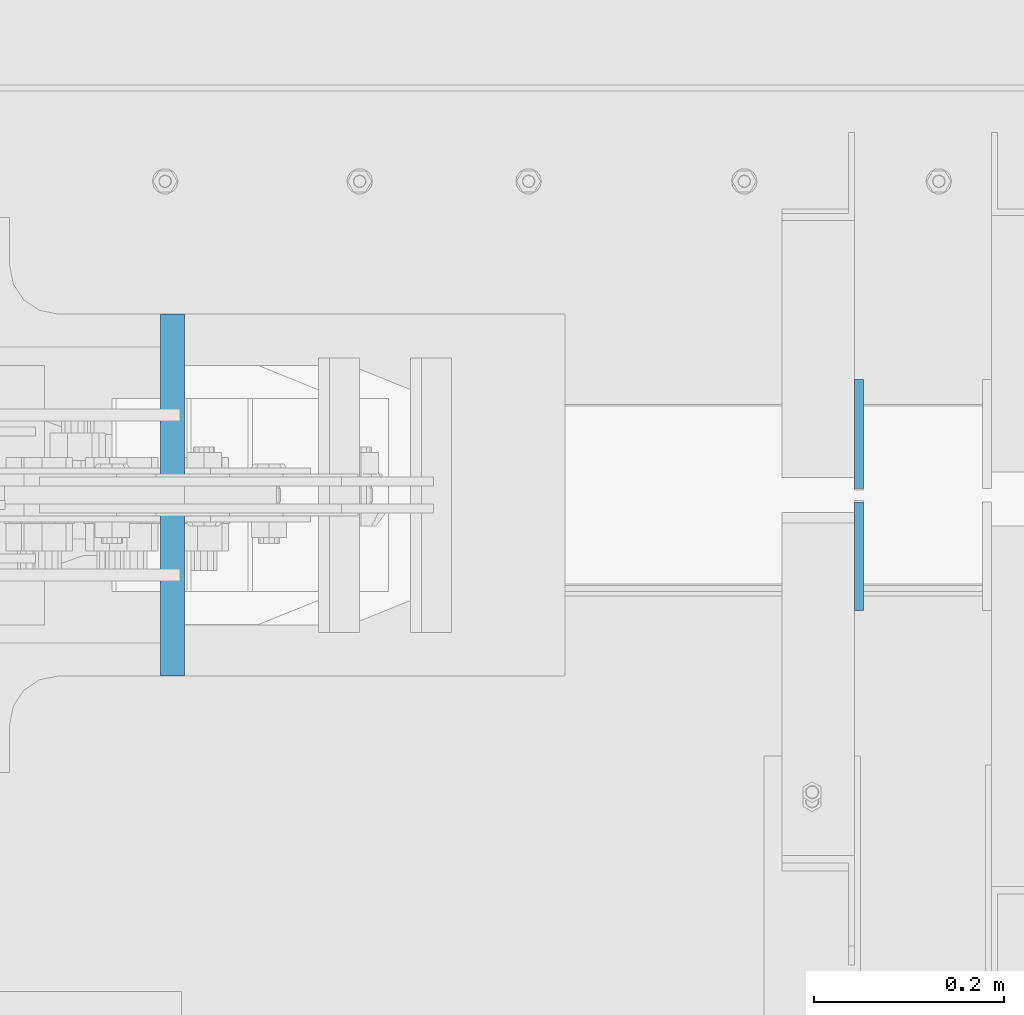
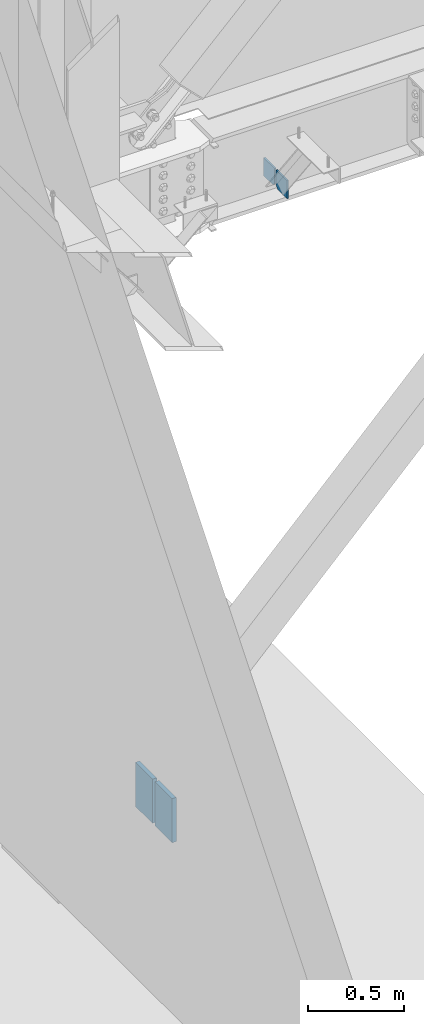
# One storey, part 510 of 1179: 4 columns, 3 elements without a shape of their own.
"""IFC2X3 building model written with IfcOpenShell, lengths in millimetres."""

from ifc_helpers import new_model, si_unit, frame, origin_with_axes, place, context, subcontext, project, spatial, faceted_brep, material, type_object, element, aggregate, save


model = new_model("IFC2X3")

# Units and contexts
model_context = context("Model", 3, precision=1e-05, world=origin_with_axes())
body_context = subcontext(model_context, "Body", "Model", "MODEL_VIEW")
ifc_project = project(units=[si_unit("LENGTHUNIT", "METRE", prefix="MILLI"), si_unit("AREAUNIT", "SQUARE_METRE"), si_unit("VOLUMEUNIT", "CUBIC_METRE"), si_unit("MASSUNIT", "GRAM", prefix="KILO"), si_unit("TIMEUNIT", "SECOND"), si_unit("PLANEANGLEUNIT", "RADIAN"), si_unit("SOLIDANGLEUNIT", "STERADIAN"), si_unit("THERMODYNAMICTEMPERATUREUNIT", "DEGREE_CELSIUS"), si_unit("LUMINOUSINTENSITYUNIT", "LUMEN")], contexts=[model_context])

# Site, building, storey
site_placement = place(None, origin_with_axes())
site = spatial("IfcSite", under=ifc_project, at=site_placement, CompositionType="ELEMENT")
building_placement = place(site_placement, origin_with_axes())
building = spatial("IfcBuilding", under=site, at=building_placement, Name="Undefined", CompositionType="ELEMENT")
storey_placement = place(building_placement, origin_with_axes())
storey = spatial("IfcBuildingStorey", under=building, at=storey_placement, Name="Undefined", CompositionType="ELEMENT", Elevation=0.0)

# Assembly, columns
assembly_1_placement = place(storey_placement, origin_with_axes())
assembly_1 = element("IfcElementAssembly", 1, at=assembly_1_placement, inside=storey, Name="BEAM", AssemblyPlace="NOTDEFINED", PredefinedType="RIGID_FRAME")
ifc_material_1 = material(Name="STEEL/A36")
column_type_1 = type_object("IfcColumnType", PredefinedType="NOTDEFINED")
column_1_placement = place(assembly_1_placement, frame((1617.6625, 41263.09375, 3576.6375), z_axis=(0.0, -1.0, 0.0), x_axis=(0.0, 0.0, 1.0)))
column_1 = element("IfcColumn", 2, at=column_1_placement, type_object=column_type_1, material=ifc_material_1, Name="PLATE", context=body_context, shape_type="Brep", body=[
    faceted_brep([(19.0500000000002, 4.76250000000073, 57.1500000000015), (0.0, 4.76250000000073, 38.0999999999985), (0.0, -4.76250000000073, 38.0999999999985), (19.0500000000002, -4.76250000000073, 57.1500000000015), (114.300000000001, 4.76250000000073, 57.1500000000015), (114.300000000001, 4.76250000000073, -57.1500000000015), (0.0, 4.76250000000073, -57.1500000000015), (114.300000000001, -4.76250000000073, 57.1500000000015), (0.0, -4.76250000000073, -57.1500000000015), (114.300000000001, -4.76250000000073, -57.1500000000015)], [[[0, 1, 2, 3]], [[4, 5, 6, 1, 0]], [[7, 4, 0, 3]], [[8, 9, 7, 3, 2]], [[8, 6, 5, 9]], [[7, 9, 5, 4]], [[6, 8, 2, 1]]]),
])
column_2_placement = place(assembly_1_placement, frame((1617.6625, 41134.50625, 3576.6375), z_axis=(0.0, 1.0, 0.0), x_axis=(0.0, 0.0, 1.0)))
column_2 = element("IfcColumn", 3, at=column_2_placement, type_object=column_type_1, material=ifc_material_1, Name="PLATE", context=body_context, shape_type="Brep", body=[
    faceted_brep([(19.0500000000002, 4.76250000000073, 57.1500000000015), (0.0, 4.76250000000073, 38.0999999999985), (0.0, -4.76250000000073, 38.0999999999985), (19.0500000000002, -4.76250000000073, 57.1500000000015), (114.300000000001, 4.76250000000073, 57.1500000000015), (114.300000000001, 4.76250000000073, -57.1500000000015), (0.0, 4.76250000000073, -57.1500000000015), (114.300000000001, -4.76250000000073, 57.1500000000015), (0.0, -4.76250000000073, -57.1500000000015), (114.300000000001, -4.76250000000073, -57.1500000000015)], [[[0, 1, 2, 3]], [[4, 5, 6, 1, 0]], [[7, 4, 0, 3]], [[8, 9, 7, 3, 2]], [[8, 6, 5, 9]], [[7, 9, 5, 4]], [[6, 8, 2, 1]]]),
])
aggregate(assembly_1, [column_1, column_2])

# Assembly, column
assembly_2_placement = place(storey_placement, origin_with_axes())
assembly_2 = element("IfcElementAssembly", 4, at=assembly_2_placement, inside=storey, Name="PLATE", AssemblyPlace="NOTDEFINED", PredefinedType="RIGID_FRAME")
ifc_material_2 = material(Name="STEEL/A572-GR.50")
column_type_2 = type_object("IfcColumnType", PredefinedType="NOTDEFINED")
column_3_placement = place(assembly_2_placement, frame((895.368453431646, 41300.4, -215.900033118257), z_axis=(0.0, -1.0, 0.0), x_axis=(0.0, 0.0, 1.0)))
column_3 = element("IfcColumn", 5, at=column_3_placement, type_object=column_type_2, material=ifc_material_2, Name="PLATE", context=body_context, shape_type="Brep", body=[
    faceted_brep([(0.0, 12.6999999999998, -88.9000000000015), (0.0, 12.6999999999998, 88.9000000000015), (280.541723827944, 12.6999999999998, 88.9000000000015), (280.541723827944, 12.6999999999998, -88.9000000000015), (0.0, -12.6999999999998, 88.9000000000015), (280.541723827944, -12.6999999999998, 88.9000000000015), (0.0, -12.6999999999998, -88.9000000000015), (280.541723827944, -12.6999999999998, -88.9000000000015)], [[[0, 1, 2, 3]], [[1, 4, 5, 2]], [[4, 6, 7, 5]], [[6, 0, 3, 7]], [[5, 7, 3, 2]], [[6, 4, 1, 0]]]),
])
aggregate(assembly_2, [column_3])

assembly_3_placement = place(storey_placement, origin_with_axes())
assembly_3 = element("IfcElementAssembly", 6, at=assembly_3_placement, inside=storey, Name="PLATE", AssemblyPlace="NOTDEFINED", PredefinedType="RIGID_FRAME")
column_4_placement = place(assembly_3_placement, frame((895.368453431646, 41097.2, -215.900033118257), z_axis=(0.0, 1.0, 0.0), x_axis=(0.0, 0.0, 1.0)))
column_4 = element("IfcColumn", 7, at=column_4_placement, type_object=column_type_2, material=ifc_material_2, Name="PLATE", context=body_context, shape_type="Brep", body=[
    faceted_brep([(0.0, 12.6999999999998, -88.9000000000015), (0.0, 12.6999999999998, 88.9000000000015), (280.541723827944, 12.6999999999998, 88.9000000000015), (280.541723827944, 12.6999999999998, -88.9000000000015), (0.0, -12.6999999999998, 88.9000000000015), (280.541723827944, -12.6999999999998, 88.9000000000015), (0.0, -12.6999999999998, -88.9000000000015), (280.541723827944, -12.6999999999998, -88.9000000000015)], [[[0, 1, 2, 3]], [[1, 4, 5, 2]], [[4, 6, 7, 5]], [[6, 0, 3, 7]], [[5, 7, 3, 2]], [[6, 4, 1, 0]]]),
])
aggregate(assembly_3, [column_4])

save(model, "model.ifc")
